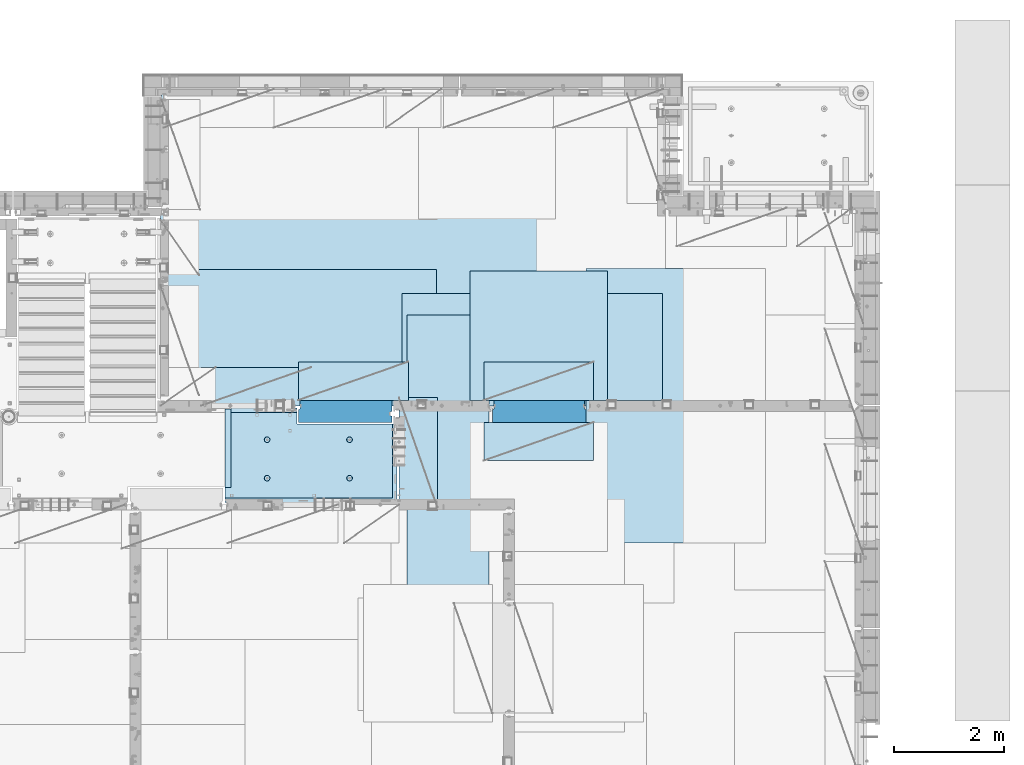
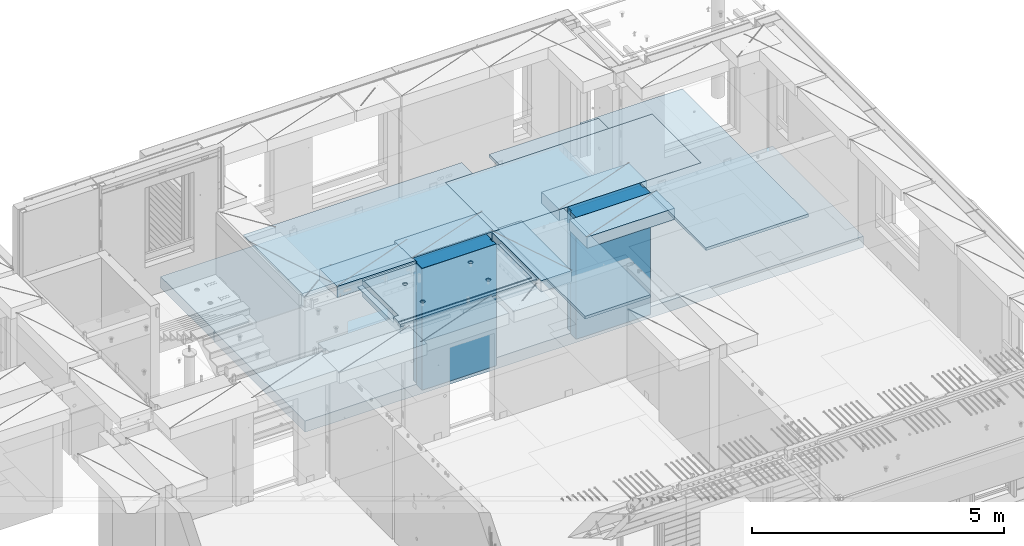
# One storey, part 189 of 325: 12 plates, 2 slabs, 14 elements without a shape of their own.
"""IFC2X3 building model written with IfcOpenShell, lengths in millimetres."""

from ifc_helpers import new_model, si_unit, frame, origin_with_axes, place, context, subcontext, project, spatial, faceted_brep, material, type_object, element, aggregate, save


model = new_model("IFC2X3")

# Units and contexts
model_context = context("Model", 3, precision=1e-05, world=origin_with_axes())
body_context = subcontext(model_context, "Body", "Model", "MODEL_VIEW")
ifc_project = project(units=[si_unit("LENGTHUNIT", "METRE", prefix="MILLI"), si_unit("AREAUNIT", "SQUARE_METRE"), si_unit("VOLUMEUNIT", "CUBIC_METRE"), si_unit("MASSUNIT", "GRAM", prefix="KILO"), si_unit("TIMEUNIT", "SECOND"), si_unit("PLANEANGLEUNIT", "RADIAN"), si_unit("SOLIDANGLEUNIT", "STERADIAN"), si_unit("THERMODYNAMICTEMPERATUREUNIT", "DEGREE_CELSIUS"), si_unit("LUMINOUSINTENSITYUNIT", "LUMEN")], contexts=[model_context])

# Site, building, storey
site_placement = place(None, origin_with_axes())
site = spatial("IfcSite", under=ifc_project, at=site_placement, CompositionType="ELEMENT")
building_placement = place(site_placement, origin_with_axes())
building = spatial("IfcBuilding", under=site, at=building_placement, CompositionType="ELEMENT")
storey_placement = place(building_placement, origin_with_axes())
storey = spatial("IfcBuildingStorey", under=building, at=storey_placement, Name="1", CompositionType="ELEMENT", Elevation=0.0)

# Assembly, slab
assembly_1_placement = place(storey_placement, origin_with_axes())
assembly_1 = element("IfcElementAssembly", 1, at=assembly_1_placement, inside=storey, AssemblyPlace="NOTDEFINED", PredefinedType="REINFORCEMENT_UNIT")
ifc_material_1 = material(Name="CONCRETE/C25/30")
slab_type_1 = type_object("IfcSlabType", PredefinedType="NOTDEFINED")
slab_1_placement = place(assembly_1_placement, frame((26570.0059390845, 15220.0026483125, 84620.0), z_axis=(-0.999999999997437, -2.26400000064461e-06, 0.0), x_axis=(-1.19799915409591e-06, 0.999999999999282, 0.0)))
slab_1 = element("IfcSlab", 2, at=slab_1_placement, type_object=slab_type_1, material=ifc_material_1, PredefinedType="FLOOR", context=body_context, shape_type="Brep", body=[
    faceted_brep([(260.000036693442, 30.0, 20.0001116859203), (260.00040878505, 30.0, 210.00282380305), (760.000392750888, 30.0, 210.001882803081), (760.000035167954, 30.0, 20.0003241859195), (259.999997532928, 50.0008466322761, 0.000110715616756352), (259.999997531775, 130.0, 4.72937244921923e-11), (260.00040878505, 130.0, 210.00282380305), (260.00003669344, 50.0008466322906, 20.0001116859239), (760.000392750888, 130.0, 210.001882803081), (759.999997530887, 50.0009701322706, 0.00188280345173553), (760.000035167954, 50.0009701322851, 20.0003241859267), (759.999997530887, 130.0, 1.4915713109076e-10), (0.0, 130.0, -1.81898940354586e-12), (0.0, 50.0007830199902, -3.63797880709171e-12), (2.23492861550767e-06, 50.0007830199902, 20.0000012144774), (0.00314200731554592, 50.0009709416772, 1679.99820316408), (0.00316042736994859, 130.0, 1679.99820316404), (20.0042037197236, 50.0007871208509, 20.0000019346335), (20.0050448999082, 50.0009732451872, 1679.9981655205), (20.0051981998968, 30.0, 1979.99816552074), (210.003723882246, 30.0, 1979.99780794351), (210.003159282247, 30.0, 1679.99780794404), (20.0050448999027, 30.0, 1679.9981655205), (20.0057858500695, 50.0011356208415, 3129.99855788155), (0.00588817475545511, 50.0011356208415, 3129.99536132812), (0.00371018100122456, 50.0010050132987, 1979.99820316354), (20.0051981998986, 50.0010068401461, 1979.99816552074), (1720.00727399273, -49.9988643791585, 3014.99216831216), (1700.0058891816, -49.9988643791585, 3014.99217713277), (1700.0058891816, 9.99999999994179, 3014.99217713277), (270.007273993393, 9.99999999994179, 3014.99280776216), (270.007273993393, -130.000000000058, 3014.99280776216), (1640.00591170533, -130.000000000058, 3014.99220359276), (1640.00591170533, -110.000000000058, 3014.99220359276), (1720.00727399273, -110.000000000058, 3014.99216831216), (1700.00578510373, 9.99999999994179, 3129.99536132812), (270.007324709519, 9.99999999994179, 3129.99536132812), (1700.00588013352, 9.99999999994179, 3024.99005271558), (270.007324709519, -130.0, 3129.99536132812), (0.0, -49.9992169800098, -3.63797880709171e-12), (1.81898940354586e-12, -110.000000000058, 0.0), (0.00588817475545511, -110.0, 3129.99536132812), (0.00588817475545511, -49.9988643791585, 3129.99536132812), (2.27349282795331e-05, -49.9992169800098, 20.000001214441), (40.0000000237706, -110.0, 0.00323799208854325), (40.0000056179106, -110.0, 80.000116817555), (80.0001648500238, -110.0, 80.0001140175445), (80.0058896111077, -110.0, 3129.99536132811), (80.0001648500238, -130.0, 80.0001140175445), (80.0058896111077, -130.0, 3129.99536132812), (458.262860973307, -110.000000000015, 813.90255309167), (472.201273869185, -110.000000000015, 821.004529187678), (483.262860973307, -110.000000000015, 832.066116291804), (490.364837069317, -110.000000000015, 846.004529187678), (492.812011254558, -110.000000000015, 861.455378906427), (490.364837069317, -110.000000000015, 876.906228625172), (483.262860973307, -110.000000000015, 890.844641521049), (472.201273869185, -110.000000000015, 901.906228625176), (458.262860973306, -110.000000000015, 909.008204721184), (442.81201125456, -110.000000000015, 911.455378906427), (427.361161535811, -110.000000000015, 909.008204721184), (413.422748639936, -110.000000000015, 901.906228625176), (402.361161535813, -110.000000000015, 890.844641521046), (395.259185439802, -110.000000000015, 876.906228625176), (392.81201125456, -110.000000000015, 861.455378906427), (395.259185439802, -110.000000000015, 846.004529187681), (402.361161535813, -110.000000000015, 832.0661162918), (413.422748639936, -110.000000000015, 821.004529187678), (427.361161535813, -110.000000000015, 813.90255309167), (442.812011254558, -110.000000000015, 811.455378906427), (458.965172324157, -130.0, 811.741061009179), (442.812011254558, -130.0, 809.182651633699), (473.537149442574, -130.0, 819.165854200462), (485.101535960521, -130.0, 830.730240718414), (492.526329151806, -130.0, 845.302217836826), (495.084738527285, -130.0, 861.45537890643), (492.526329151804, -130.0, 877.608539976027), (485.101535960521, -130.0, 892.180517094443), (473.537149442574, -130.0, 903.744903612387), (458.965172324157, -130.0, 911.16969680367), (442.81201125456, -130.0, 913.728106179151), (426.658850184962, -130.0, 911.169696803674), (412.086873066544, -130.0, 903.744903612391), (400.522486548598, -130.0, 892.180517094443), (393.097693357315, -130.0, 877.608539976027), (390.539283981834, -130.0, 861.455378906427), (393.097693357317, -130.0, 845.302217836826), (400.522486548598, -130.0, 830.730240718414), (412.086873066544, -130.0, 819.165854200462), (426.658850184962, -130.0, 811.741061009183), (1158.26361347154, -110.000000000058, 2313.90608356011), (1172.20202636741, -110.000000000058, 2321.00805965612), (1183.26361347154, -110.000000000058, 2332.06964676024), (1190.36558956755, -110.000000000058, 2346.00805965611), (1192.81276375279, -110.000000000058, 2361.45890937486), (1190.36558956755, -110.000000000058, 2376.90975909361), (1183.26361347154, -110.000000000058, 2390.84817198949), (1172.20202636741, -110.000000000058, 2401.90975909361), (1158.26361347154, -110.000000000058, 2409.01173518962), (1142.81276375279, -110.000000000058, 2411.45890937487), (1127.36191403404, -110.000000000058, 2409.01173518962), (1113.42350113817, -110.000000000058, 2401.90975909361), (1102.36191403404, -110.000000000058, 2390.84817198948), (1095.25993793803, -110.000000000058, 2376.90975909361), (1092.81276375279, -110.000000000058, 2361.45890937486), (1095.25993793803, -110.000000000058, 2346.00805965612), (1102.36191403404, -110.000000000058, 2332.06964676024), (1113.42350113817, -110.000000000058, 2321.00805965611), (1127.36191403405, -110.000000000058, 2313.90608356011), (1142.81276375279, -110.000000000058, 2311.45890937486), (1158.96592482239, -130.000000000044, 2311.74459147762), (1142.81276375279, -130.000000000044, 2309.18618210214), (1173.5379019408, -130.000000000044, 2319.1693846689), (1185.10228845875, -130.000000000044, 2330.73377118685), (1192.52708165004, -130.000000000044, 2345.30574830526), (1195.08549102551, -130.000000000044, 2361.45890937486), (1192.52708165004, -130.000000000044, 2377.61207044447), (1185.10228845875, -130.000000000044, 2392.18404756288), (1173.5379019408, -130.000000000044, 2403.74843408083), (1158.96592482239, -130.000000000044, 2411.17322727211), (1142.81276375279, -130.000000000044, 2413.73163664759), (1126.65960268319, -130.000000000044, 2411.17322727211), (1112.08762556478, -130.000000000044, 2403.74843408083), (1100.52323904683, -130.000000000044, 2392.18404756287), (1093.09844585554, -130.000000000044, 2377.61207044447), (1090.54003648007, -130.000000000044, 2361.45890937486), (1093.09844585555, -130.000000000044, 2345.30574830526), (1100.52323904683, -130.000000000044, 2330.73377118685), (1112.08762556478, -130.000000000044, 2319.1693846689), (1126.65960268319, -130.000000000044, 2311.74459147762), (1158.26322681425, -110.000000000029, 813.902566246979), (1172.20163971013, -110.000000000029, 821.004542342987), (1183.26322681425, -110.000000000029, 832.066129447114), (1190.36520291026, -110.000000000029, 846.004542342987), (1192.8123770955, -110.000000000029, 861.455392061736), (1190.36520291026, -110.000000000029, 876.906241780482), (1183.26322681425, -110.000000000029, 890.844654676363), (1172.20163971012, -110.000000000029, 901.906241780485), (1158.26322681425, -110.000000000029, 909.008217876493), (1142.8123770955, -110.000000000029, 911.455392061736), (1127.36152737675, -110.000000000029, 909.008217876493), (1113.42311448088, -110.000000000029, 901.906241780485), (1102.36152737675, -110.000000000029, 890.844654676359), (1095.25955128074, -110.000000000029, 876.906241780485), (1092.8123770955, -110.000000000029, 861.45539206174), (1095.25955128074, -110.000000000029, 846.004542342991), (1102.36152737675, -110.000000000029, 832.06612944711), (1113.42311448088, -110.000000000029, 821.004542342987), (1127.36152737675, -110.000000000029, 813.902566246979), (1142.8123770955, -110.000000000029, 811.455392061736), (1158.9655381651, -130.000000000029, 811.741074164489), (1142.8123770955, -130.000000000029, 809.182664789012), (1173.53751528352, -130.000000000029, 819.165867355772), (1185.10190180146, -130.000000000029, 830.730253873724), (1192.52669499275, -130.000000000029, 845.302230992136), (1195.08510436823, -130.000000000029, 861.45539206174), (1192.52669499275, -130.000000000029, 877.608553131337), (1185.10190180146, -130.000000000029, 892.180530249756), (1173.53751528351, -130.000000000029, 903.744916767697), (1158.9655381651, -130.000000000029, 911.16970995898), (1142.8123770955, -130.000000000029, 913.728119334461), (1126.6592160259, -130.000000000029, 911.169709958984), (1112.08723890749, -130.000000000029, 903.7449167677), (1100.52285238954, -130.000000000029, 892.180530249752), (1093.09805919825, -130.000000000029, 877.608553131337), (1090.53964982277, -130.000000000015, 861.455392061736), (1093.09805919826, -130.000000000015, 845.302230992136), (1100.52285238954, -130.000000000015, 830.730253873724), (1112.08723890749, -130.000000000015, 819.165867355776), (1126.6592160259, -130.000000000015, 811.741074164493), (458.263613472778, -110.000000000058, 2313.90740096011), (472.202026368655, -110.000000000058, 2321.00937705611), (483.263613472776, -110.000000000058, 2332.07096416024), (490.365589568788, -110.000000000058, 2346.00937705611), (492.812763754029, -110.000000000058, 2361.46022677486), (490.365589568788, -110.000000000058, 2376.91107649361), (483.263613472778, -110.000000000058, 2390.84948938949), (472.202026368655, -110.000000000058, 2401.91107649361), (458.263613472776, -110.000000000058, 2409.01305258962), (442.812763754029, -110.000000000058, 2411.46022677486), (427.361914035282, -110.000000000058, 2409.01305258962), (413.423501139407, -110.000000000058, 2401.91107649361), (402.361914035284, -110.000000000058, 2390.84948938949), (395.259937939272, -110.000000000058, 2376.91107649361), (392.812763754031, -110.000000000058, 2361.46022677486), (395.259937939272, -110.000000000058, 2346.00937705612), (402.361914035284, -110.000000000058, 2332.07096416024), (413.423501139407, -110.000000000058, 2321.00937705611), (427.361914035284, -110.000000000058, 2313.90740096011), (442.812763754029, -110.000000000058, 2311.46022677486), (458.965924823628, -130.000000000029, 2311.74590887762), (442.812763754029, -130.000000000029, 2309.18749950214), (473.537901942043, -130.000000000029, 2319.1707020689), (485.10228845999, -130.000000000029, 2330.73508858685), (492.527081651273, -130.000000000029, 2345.30706570526), (495.085491026754, -130.000000000029, 2361.46022677486), (492.527081651273, -130.000000000029, 2377.61338784446), (485.102288459992, -130.000000000029, 2392.18536496288), (473.537901942043, -130.000000000029, 2403.74975148082), (458.965924823628, -130.000000000029, 2411.1745446721), (442.812763754031, -130.000000000029, 2413.73295404758), (426.659602684433, -130.000000000029, 2411.17454467211), (412.087625566017, -130.000000000029, 2403.74975148082), (400.523239048071, -130.000000000029, 2392.18536496288), (393.098445856787, -130.000000000029, 2377.61338784446), (390.540036481307, -130.000000000029, 2361.46022677486), (393.098445856789, -130.000000000029, 2345.30706570526), (400.523239048067, -130.000000000029, 2330.73508858685), (412.087625566017, -130.000000000029, 2319.17070206891), (426.659602684433, -130.000000000029, 2311.74590887762), (1640.0069692709, -130.000000000058, 1820.00285259458), (1429.99412576448, -130.0, 80.0005450159842), (1430.00077693619, -130.000000000044, 1820.00324782623), (1640.0069692709, -110.000000000058, 1820.00285259458), (1720.00719314726, -110.000000000058, 1820.00270203416), (1720.00719416424, -49.9988643791585, 1820.00270203415), (1700.00697064704, -49.9988643791585, 1820.00273967458), (1430.00077693619, 129.999999999985, 1820.00324782623), (1720.00507313573, 130.0, 1820.00270203815), (1720.00696350816, 50.0011356208415, 1820.00270203459), (1700.00697064704, 50.0011356208415, 1820.00273967458), (1720.00548380367, 130.0, 2629.9953613439), (1720.00479630696, 50.0011356208415, 2629.99536134425), (1700.00623760369, 50.0011356208415, 2629.99539898154), (1700.00623760369, 30.0, 2629.99539898154), (1700.00578510373, 30.0, 3129.99535793147), (1510.00479630733, 130.0, 2629.99575656425), (1510.00479630733, 30.0, 2629.99575656425), (1510.00573730659, 130.0, 3129.99536132812), (1510.00573730659, 30.0, 3129.99536134176), (0.00588817475545511, 130.0, 3129.99536132812), (20.0057858500695, -49.9988643791585, 3129.99855788155), (0.00372479000361636, 130.0, 1979.99820316351), (210.003723882246, 130.0, 1979.99780794351), (210.003159282247, 130.0, 1679.99780794404), (20.0042037196527, -49.9988643791585, 20.0000019345935), (20.0041864226587, -49.9992128791491, 7.34271452529356e-07), (1429.99419217423, -49.9988643791585, 20.0006089333838), (1429.99420067423, -49.9988643791585, 0.000608933383773547), (80.0000146155362, -110.0, 0.000114017555461032), (1429.99735169022, -110.0, 7.40013310860377e-05), (1429.99412576448, -110.0, 80.0005450159842), (1429.99416747423, 50.0011356208415, 20.0006089334311), (1429.99417597423, 50.0011356208415, 0.000608933431067271), (1429.99735169022, 130.0, 2.80124368146062e-10), (20.0041864225386, 50.0007871208509, -3.03407432511449e-09)], [[[0, 1, 2, 3]], [[4, 5, 6, 1, 0, 7]], [[8, 2, 1, 6]], [[9, 10, 3, 2, 8, 11]], [[12, 13, 14, 15, 16]], [[14, 17, 18, 15]], [[19, 20, 21, 22]], [[23, 24, 25, 26]], [[27, 28, 29, 30, 31, 32, 33, 34]], [[35, 36, 30, 29, 37]], [[31, 30, 36, 38]], [[39, 40, 41, 42, 43]], [[44, 45, 46, 47, 41, 40]], [[48, 49, 47, 46]], [[50, 51, 52, 53, 54, 55, 56, 57, 58, 59, 60, 61, 62, 63, 64, 65, 66, 67, 68, 69]], [[70, 50, 69, 71]], [[72, 51, 50, 70]], [[73, 52, 51, 72]], [[74, 53, 52, 73]], [[75, 54, 53, 74]], [[76, 55, 54, 75]], [[77, 56, 55, 76]], [[78, 57, 56, 77]], [[79, 58, 57, 78]], [[80, 59, 58, 79]], [[81, 60, 59, 80]], [[82, 61, 60, 81]], [[83, 62, 61, 82]], [[84, 63, 62, 83]], [[85, 64, 63, 84]], [[86, 65, 64, 85]], [[87, 66, 65, 86]], [[88, 67, 66, 87]], [[89, 68, 67, 88]], [[71, 69, 68, 89]], [[90, 91, 92, 93, 94, 95, 96, 97, 98, 99, 100, 101, 102, 103, 104, 105, 106, 107, 108, 109]], [[110, 90, 109, 111]], [[112, 91, 90, 110]], [[113, 92, 91, 112]], [[114, 93, 92, 113]], [[115, 94, 93, 114]], [[116, 95, 94, 115]], [[117, 96, 95, 116]], [[118, 97, 96, 117]], [[119, 98, 97, 118]], [[120, 99, 98, 119]], [[121, 100, 99, 120]], [[122, 101, 100, 121]], [[123, 102, 101, 122]], [[124, 103, 102, 123]], [[125, 104, 103, 124]], [[126, 105, 104, 125]], [[127, 106, 105, 126]], [[128, 107, 106, 127]], [[129, 108, 107, 128]], [[111, 109, 108, 129]], [[130, 131, 132, 133, 134, 135, 136, 137, 138, 139, 140, 141, 142, 143, 144, 145, 146, 147, 148, 149]], [[150, 130, 149, 151]], [[152, 131, 130, 150]], [[153, 132, 131, 152]], [[154, 133, 132, 153]], [[155, 134, 133, 154]], [[156, 135, 134, 155]], [[157, 136, 135, 156]], [[158, 137, 136, 157]], [[159, 138, 137, 158]], [[160, 139, 138, 159]], [[161, 140, 139, 160]], [[162, 141, 140, 161]], [[163, 142, 141, 162]], [[164, 143, 142, 163]], [[165, 144, 143, 164]], [[166, 145, 144, 165]], [[167, 146, 145, 166]], [[168, 147, 146, 167]], [[169, 148, 147, 168]], [[151, 149, 148, 169]], [[170, 171, 172, 173, 174, 175, 176, 177, 178, 179, 180, 181, 182, 183, 184, 185, 186, 187, 188, 189]], [[190, 170, 189, 191]], [[192, 171, 170, 190]], [[193, 172, 171, 192]], [[194, 173, 172, 193]], [[195, 174, 173, 194]], [[196, 175, 174, 195]], [[197, 176, 175, 196]], [[198, 177, 176, 197]], [[199, 178, 177, 198]], [[200, 179, 178, 199]], [[201, 180, 179, 200]], [[202, 181, 180, 201]], [[203, 182, 181, 202]], [[204, 183, 182, 203]], [[205, 184, 183, 204]], [[206, 185, 184, 205]], [[207, 186, 185, 206]], [[208, 187, 186, 207]], [[209, 188, 187, 208]], [[191, 189, 188, 209]], [[210, 32, 31, 38, 49, 48, 211, 212], [208, 207, 206, 205, 204, 203, 202, 201, 200, 199, 198, 197, 196, 195, 194, 193, 192, 190, 191, 209], [168, 167, 166, 165, 164, 163, 162, 161, 160, 159, 158, 157, 156, 155, 154, 153, 152, 150, 151, 169], [128, 127, 126, 125, 124, 123, 122, 121, 120, 119, 118, 117, 116, 115, 114, 113, 112, 110, 111, 129], [88, 87, 86, 85, 84, 83, 82, 81, 80, 79, 78, 77, 76, 75, 74, 73, 72, 70, 71, 89]], [[33, 32, 210, 213]], [[34, 33, 213, 214]], [[27, 34, 214, 215]], [[28, 27, 215, 216]], [[214, 213, 210, 212, 217, 218, 219, 220, 216, 215]], [[219, 218, 221, 222]], [[220, 219, 222, 223]], [[35, 37, 29, 28, 216, 220, 223, 224, 225]], [[222, 221, 226, 227, 224, 223]], [[228, 229, 227, 226]], [[224, 227, 229, 225]], [[228, 230, 24, 23, 231, 42, 41, 47, 49, 38, 36, 35, 225, 229]], [[24, 230, 232, 25]], [[233, 20, 19, 26, 25, 232]], [[234, 21, 20, 233]], [[16, 15, 18, 22, 21, 234]], [[17, 235, 231, 23, 26, 19, 22, 18]], [[43, 42, 231, 235]], [[236, 39, 43, 235, 237, 238]], [[239, 44, 40, 39, 236, 238, 240]], [[46, 45, 44, 239, 240, 241]], [[48, 46, 241, 211]], [[240, 238, 237, 242, 243, 244, 217, 212, 211, 241]], [[244, 243, 9, 11]], [[6, 5, 12, 16, 234, 233, 232, 230, 228, 226, 221, 218, 217, 244, 11, 8]], [[245, 13, 12, 5, 4]], [[17, 14, 13, 245, 4, 7]], [[242, 237, 235, 17, 7, 0, 3, 10]], [[243, 242, 10, 9]]]),
])
aggregate(assembly_1, [slab_1])

assembly_2_placement = place(storey_placement, origin_with_axes())
assembly_2 = element("IfcElementAssembly", 3, at=assembly_2_placement, inside=storey, AssemblyPlace="NOTDEFINED", PredefinedType="REINFORCEMENT_UNIT")
ifc_material_2 = material(Name="CONCRETE/C30/37")
slab_type_2 = type_object("IfcSlabType", PredefinedType="NOTDEFINED")
slab_2_placement = place(assembly_2_placement, frame((22310.0, 16980.0, 81595.0), z_axis=(0.0, 1.0, 0.0), x_axis=(1.0, 0.0, 0.0)))
slab_2 = element("IfcSlab", 4, at=slab_2_placement, type_object=slab_type_2, material=ifc_material_2, PredefinedType="FLOOR", context=body_context, shape_type="Brep", body=[
    faceted_brep([(1.81898940354586e-12, -135.0, 1.81898940354586e-12), (-39.9985427856445, -135.0, -0.0037095642182976), (-39.9985427856445, 135.0, -0.0037095642182976), (1.81898940354586e-12, 135.0, 1.81898940354586e-12), (-40.0, -135.0, 3600.00048828125), (-40.0, 135.0, 3600.00048828125), (-20.0, -135.0, 3600.0), (-20.0, 135.0, 3600.0), (-20.0, -135.0, 5760.0), (-20.0, 135.0, 5760.0), (9149.9990234375, -135.0, 5760.0), (9149.9990234375, 135.0, 5760.0), (9149.9990234375, -135.0, 3600.00073242188), (9149.9990234375, 135.0, 3600.00073242188), (12750.0, -135.0, 3599.9951171875), (12750.0, 135.0, 3599.9951171875), (12750.0, -135.0, 0.0), (12750.0, 135.0, 0.0)], [[[0, 1, 2, 3]], [[1, 4, 5, 2]], [[4, 6, 7, 5]], [[6, 8, 9, 7]], [[8, 10, 11, 9]], [[10, 12, 13, 11]], [[12, 14, 15, 13]], [[14, 16, 17, 15]], [[16, 0, 3, 17]], [[5, 7, 9, 11, 13, 15, 17, 3, 2]], [[16, 14, 12, 10, 8, 6, 4, 1, 0]]]),
])
aggregate(assembly_2, [slab_2])

# Assembly, plate
assembly_3_placement = place(storey_placement, origin_with_axes())
assembly_3 = element("IfcElementAssembly", 5, at=assembly_3_placement, inside=storey, Name="Steel Assembly", AssemblyPlace="NOTDEFINED", PredefinedType="NOTDEFINED")
ifc_material_3 = material()
plate_type_1 = type_object("IfcPlateType", PredefinedType="NOTDEFINED")
plate_1_placement = place(assembly_3_placement, frame((22289.9998779297, 19460.0009765625, 84695.1), z_axis=(1.0, 0.0, 0.0), x_axis=(0.0, -1.0, 0.0)))
plate_1 = element("IfcPlate", 6, at=plate_1_placement, type_object=plate_type_1, material=ifc_material_3, context=body_context, shape_type="Brep", body=[
    faceted_brep([(0.0, -35.0, 0.0), (0.0, -35.0, 5000.0), (0.0, 35.0, 5000.0), (0.0, 35.0, 0.0), (2349.99951171875, -35.0, 5000.0), (2349.99951171875, 35.0, 5000.0), (2350.0, -35.0, 0.0), (2350.0, 35.0, 0.0)], [[[0, 1, 2, 3]], [[1, 4, 5, 2]], [[4, 6, 7, 5]], [[6, 0, 3, 7]], [[5, 7, 3, 2]], [[6, 4, 1, 0]]]),
])
aggregate(assembly_3, [plate_1])

assembly_4_placement = place(storey_placement, origin_with_axes())
assembly_4 = element("IfcElementAssembly", 7, at=assembly_4_placement, inside=storey, Name="Steel Assembly", AssemblyPlace="NOTDEFINED", PredefinedType="NOTDEFINED")
plate_2_placement = place(assembly_4_placement, frame((27902.5, 19430.0, 84695.1), z_axis=(1.0, 0.0, 0.0), x_axis=(0.0, -1.0, 0.0)))
plate_2 = element("IfcPlate", 8, at=plate_2_placement, type_object=plate_type_1, material=ifc_material_3, Name="1/2", context=body_context, shape_type="Brep", body=[
    faceted_brep([(0.0, -35.0, 0.0), (0.0, -35.0, 2500.0), (0.0, 35.0, 2500.0), (0.0, 35.0, 0.0), (2349.99951171875, -35.0, 2500.0), (2349.99951171875, 35.0, 2500.0), (2350.0, -35.0, 0.0), (2350.0, 35.0, 0.0)], [[[0, 1, 2, 3]], [[1, 4, 5, 2]], [[4, 6, 7, 5]], [[6, 0, 3, 7]], [[5, 7, 3, 2]], [[6, 4, 1, 0]]]),
])
aggregate(assembly_4, [plate_2])

assembly_5_placement = place(storey_placement, origin_with_axes())
assembly_5 = element("IfcElementAssembly", 9, at=assembly_5_placement, inside=storey, Name="Steel Assembly", AssemblyPlace="NOTDEFINED", PredefinedType="NOTDEFINED")
plate_3_placement = place(assembly_5_placement, frame((32360.0, 19480.0, 84695.1), z_axis=(0.0, -1.0, 0.0), x_axis=(-1.0, 3.00000001838171e-08, 0.0)))
plate_3 = element("IfcPlate", 10, at=plate_3_placement, type_object=plate_type_1, material=ifc_material_3, context=body_context, shape_type="Brep", body=[
    faceted_brep([(0.0, -35.0, 0.0), (0.0, -35.0, 5000.0), (0.0, 35.0, 5000.0), (0.0, 35.0, 0.0), (2349.99951171875, -35.0, 5000.0), (2349.99951171875, 35.0, 5000.0), (2350.0, -35.0, 0.0), (2350.0, 35.0, 0.0)], [[[0, 1, 2, 3]], [[1, 4, 5, 2]], [[4, 6, 7, 5]], [[6, 0, 3, 7]], [[5, 7, 3, 2]], [[6, 4, 1, 0]]]),
])
aggregate(assembly_5, [plate_3])

assembly_6_placement = place(storey_placement, origin_with_axes())
assembly_6 = element("IfcElementAssembly", 11, at=assembly_6_placement, inside=storey, Name="Steel Assembly", AssemblyPlace="NOTDEFINED", PredefinedType="NOTDEFINED")
plate_type_2 = type_object("IfcPlateType", PredefinedType="NOTDEFINED")
plate_4_placement = place(assembly_6_placement, frame((28250.0000122641, 18630.0, 84695.1000003815), z_axis=(0.0, -1.0, 0.0), x_axis=(-1.0, 3.00000001838171e-08, 0.0)))
plate_4 = element("IfcPlate", 12, at=plate_4_placement, type_object=plate_type_2, material=ifc_material_3, context=body_context, shape_type="Brep", body=[
    faceted_brep([(0.0, -35.0, 0.0), (0.0, -35.0, 5000.0), (0.0, 35.0, 5000.0), (0.0, 35.0, 0.0), (1499.99951171875, -35.0, 5000.0), (1499.99951171875, 35.0, 5000.0), (1500.0, -35.0, 0.0), (1500.0, 35.0, 0.0)], [[[0, 1, 2, 3]], [[1, 4, 5, 2]], [[4, 6, 7, 5]], [[6, 0, 3, 7]], [[5, 7, 3, 2]], [[6, 4, 1, 0]]]),
])
aggregate(assembly_6, [plate_4])

assembly_7_placement = place(storey_placement, origin_with_axes())
assembly_7 = element("IfcElementAssembly", 13, at=assembly_7_placement, inside=storey, Name="Steel Assembly", AssemblyPlace="NOTDEFINED", PredefinedType="NOTDEFINED")
plate_type_3 = type_object("IfcPlateType", PredefinedType="NOTDEFINED")
plate_5_placement = place(assembly_7_placement, frame((23010.0008542386, 16980.0001036336, 84595.3), z_axis=(0.0, 1.0, 0.0), x_axis=(1.0, 0.0, 0.0)))
plate_5 = element("IfcPlate", 14, at=plate_5_placement, type_object=plate_type_3, material=ifc_material_3, Name="RE1", context=body_context, shape_type="Brep", body=[
    faceted_brep([(1.81898940354586e-12, -135.0, 1.81898940354586e-12), (0.0, -135.0, 699.999999999996), (0.0, 135.0, 699.999999999996), (1.81898940354586e-12, 135.0, 1.81898940354586e-12), (1999.99951171875, -135.0, 699.999999999993), (1999.99951171875, 135.0, 699.999999999993), (2000.0, -135.0, -3.63797880709171e-12), (2000.0, 135.0, -3.63797880709171e-12)], [[[0, 1, 2, 3]], [[1, 4, 5, 2]], [[4, 6, 7, 5]], [[6, 0, 3, 7]], [[5, 7, 3, 2]], [[6, 4, 1, 0]]]),
])
aggregate(assembly_7, [plate_5])

assembly_8_placement = place(storey_placement, origin_with_axes())
assembly_8 = element("IfcElementAssembly", 15, at=assembly_8_placement, inside=storey, Name="Steel Assembly", AssemblyPlace="NOTDEFINED", PredefinedType="NOTDEFINED")
plate_6_placement = place(assembly_8_placement, frame((30152.4991457614, 16679.9998963664, 84595.3), z_axis=(0.0, -1.0, 0.0), x_axis=(-1.0, 3.00000001838171e-08, 0.0)))
plate_6 = element("IfcPlate", 16, at=plate_6_placement, type_object=plate_type_3, material=ifc_material_3, Name="RE1", context=body_context, shape_type="Brep", body=[
    faceted_brep([(1.81898940354586e-12, -135.0, 1.81898940354586e-12), (0.0, -135.0, 699.999999999996), (0.0, 135.0, 699.999999999996), (1.81898940354586e-12, 135.0, 1.81898940354586e-12), (1999.99951171875, -135.0, 699.999999999993), (1999.99951171875, 135.0, 699.999999999993), (2000.0, -135.0, -3.63797880709171e-12), (2000.0, 135.0, -3.63797880709171e-12)], [[[0, 1, 2, 3]], [[1, 4, 5, 2]], [[4, 6, 7, 5]], [[6, 0, 3, 7]], [[5, 7, 3, 2]], [[6, 4, 1, 0]]]),
])
aggregate(assembly_8, [plate_6])

assembly_9_placement = place(storey_placement, origin_with_axes())
assembly_9 = element("IfcElementAssembly", 17, at=assembly_9_placement, inside=storey, Name="Steel Assembly", AssemblyPlace="NOTDEFINED", PredefinedType="NOTDEFINED")
plate_7_placement = place(assembly_9_placement, frame((28152.5008542386, 17080.0001036336, 84595.3), z_axis=(0.0, 1.0, 0.0), x_axis=(1.0, 0.0, 0.0)))
plate_7 = element("IfcPlate", 18, at=plate_7_placement, type_object=plate_type_3, material=ifc_material_3, Name="RE1", context=body_context, shape_type="Brep", body=[
    faceted_brep([(1.81898940354586e-12, -135.0, 1.81898940354586e-12), (0.0, -135.0, 699.999999999996), (0.0, 135.0, 699.999999999996), (1.81898940354586e-12, 135.0, 1.81898940354586e-12), (1999.99951171875, -135.0, 699.999999999993), (1999.99951171875, 135.0, 699.999999999993), (2000.0, -135.0, -3.63797880709171e-12), (2000.0, 135.0, -3.63797880709171e-12)], [[[0, 1, 2, 3]], [[1, 4, 5, 2]], [[4, 6, 7, 5]], [[6, 0, 3, 7]], [[5, 7, 3, 2]], [[6, 4, 1, 0]]]),
])
aggregate(assembly_9, [plate_7])

assembly_10_placement = place(storey_placement, origin_with_axes())
assembly_10 = element("IfcElementAssembly", 19, at=assembly_10_placement, inside=storey, Name="Steel Assembly", AssemblyPlace="NOTDEFINED", PredefinedType="NOTDEFINED")
plate_8_placement = place(assembly_10_placement, frame((24780.0008542386, 17080.0001036336, 84595.3), z_axis=(0.0, 1.0, 0.0), x_axis=(1.0, 0.0, 0.0)))
plate_8 = element("IfcPlate", 20, at=plate_8_placement, type_object=plate_type_3, material=ifc_material_3, Name="RE1", context=body_context, shape_type="Brep", body=[
    faceted_brep([(1.81898940354586e-12, -135.0, 1.81898940354586e-12), (0.0, -135.0, 699.999999999996), (0.0, 135.0, 699.999999999996), (1.81898940354586e-12, 135.0, 1.81898940354586e-12), (1999.99951171875, -135.0, 699.999999999993), (1999.99951171875, 135.0, 699.999999999993), (2000.0, -135.0, -3.63797880709171e-12), (2000.0, 135.0, -3.63797880709171e-12)], [[[0, 1, 2, 3]], [[1, 4, 5, 2]], [[4, 6, 7, 5]], [[6, 0, 3, 7]], [[5, 7, 3, 2]], [[6, 4, 1, 0]]]),
])
aggregate(assembly_10, [plate_8])

assembly_11_placement = place(storey_placement, origin_with_axes())
assembly_11 = element("IfcElementAssembly", 21, at=assembly_11_placement, inside=storey, Name="Steel Assembly", AssemblyPlace="NOTDEFINED", PredefinedType="NOTDEFINED")
plate_9_placement = place(assembly_11_placement, frame((26609.9998779297, 17130.0, 84595.3), z_axis=(1.0, 0.0, 0.0), x_axis=(0.0, -1.0, 0.0)))
plate_9 = element("IfcPlate", 22, at=plate_9_placement, type_object=plate_type_3, material=ifc_material_3, Name="RE1", context=body_context, shape_type="Brep", body=[
    faceted_brep([(1.81898940354586e-12, -135.0, 1.81898940354586e-12), (0.0, -135.0, 699.999999999996), (0.0, 135.0, 699.999999999996), (1.81898940354586e-12, 135.0, 1.81898940354586e-12), (1999.99951171875, -135.0, 699.999999999993), (1999.99951171875, 135.0, 699.999999999993), (2000.0, -135.0, -3.63797880709171e-12), (2000.0, 135.0, -3.63797880709171e-12)], [[[0, 1, 2, 3]], [[1, 4, 5, 2]], [[4, 6, 7, 5]], [[6, 0, 3, 7]], [[5, 7, 3, 2]], [[6, 4, 1, 0]]]),
])
aggregate(assembly_11, [plate_9])

assembly_12_placement = place(storey_placement, origin_with_axes())
assembly_12 = element("IfcElementAssembly", 23, at=assembly_12_placement, inside=storey, AssemblyPlace="NOTDEFINED", PredefinedType="REINFORCEMENT_UNIT")
plate_type_4 = type_object("IfcPlateType", PredefinedType="NOTDEFINED")
plate_10_placement = place(assembly_12_placement, frame((31402.0004441066, 19019.9993561238, 84725.45), z_axis=(0.0, -1.0, 0.0), x_axis=(-1.0, 3.00000001838171e-08, 0.0)))
plate_10 = element("IfcPlate", 24, at=plate_10_placement, type_object=plate_type_4, material=ifc_material_3, context=body_context, shape_type="Brep", body=[
    faceted_brep([(0.0, -5.0, 0.0), (0.0, -5.0, 1939.99963378906), (0.0, 5.0, 1939.99963378906), (0.0, 5.0, 0.0), (4742.00048828125, -5.0, 1939.99963378906), (4742.00048828125, 5.0, 1939.99963378906), (4742.00048828125, -5.0, 0.0), (4742.00048828125, 5.0, 0.0), (92.0009613037109, -5.0, 0.0), (92.0009613037109, 5.0, 0.0)], [[[0, 1, 2, 3]], [[1, 4, 5, 2]], [[4, 6, 7, 5]], [[6, 8, 9, 7]], [[8, 0, 3, 9]], [[5, 7, 9, 3, 2]], [[8, 6, 4, 1, 0]]]),
])
aggregate(assembly_12, [plate_10])

assembly_13_placement = place(storey_placement, origin_with_axes())
assembly_13 = element("IfcElementAssembly", 25, at=assembly_13_placement, inside=storey, Name="Steel Assembly", AssemblyPlace="NOTDEFINED", PredefinedType="NOTDEFINED")
ifc_material_4 = material()
plate_type_5 = type_object("IfcPlateType", PredefinedType="NOTDEFINED")
plate_11_placement = place(assembly_13_placement, frame((24780.0, 16680.0, 83255.6000003815), z_axis=(0.0, 1.0, 0.0), x_axis=(1.0, 0.0, 0.0)))
plate_11 = element("IfcPlate", 26, at=plate_11_placement, type_object=plate_type_5, material=ifc_material_4, context=body_context, shape_type="Brep", body=[
    faceted_brep([(1699.99914550781, -1475.0, 110.0), (1699.99914550781, 1475.0, 110.0), (1669.99914550781, 1475.0, 110.0), (1669.99914550781, -1475.00000000001, 110.0), (1669.99914550781, 1475.0, 200.0), (1669.99914550781, -1475.00000000001, 200.0), (1699.99914550781, -1475.0, 200.0), (1699.99914550781, 1475.0, 200.0), (1699.99914550781, -1475.0, 3.63797880709171e-12), (0.0, -1475.0, 0.0), (0.0, 1475.0, 0.0), (1699.99914550781, 1475.0, 3.63797880709171e-12), (0.0, -1475.0, 230.0), (0.0, 1475.0, 230.0), (30.0, -1475.0, 243.0), (30.0, 1475.0, 243.0), (30.0, -1475.0, 400.0), (30.0, 1475.0, 400.0), (1699.99914550781, -1475.0, 400.0), (1699.99914550781, 1475.0, 400.0)], [[[0, 1, 2, 3]], [[3, 2, 4, 5]], [[6, 5, 4, 7]], [[8, 9, 10, 11]], [[10, 9, 12, 13]], [[14, 15, 13, 12]], [[16, 17, 15, 14]], [[18, 19, 17, 16]], [[19, 18, 6, 7]], [[2, 1, 11, 10, 13, 15, 17, 19, 7, 4]], [[8, 11, 1, 0]], [[18, 16, 14, 12, 9, 8, 0, 3, 5, 6]]]),
])
aggregate(assembly_13, [plate_11])

assembly_14_placement = place(storey_placement, origin_with_axes())
assembly_14 = element("IfcElementAssembly", 27, at=assembly_14_placement, inside=storey, Name="Steel Assembly", AssemblyPlace="NOTDEFINED", PredefinedType="NOTDEFINED")
plate_12_placement = place(assembly_14_placement, frame((28309.9999105288, 16680.0000293051, 83255.6000003815), z_axis=(0.0, 1.0, 0.0), x_axis=(1.0, 0.0, 0.0)))
plate_12 = element("IfcPlate", 28, at=plate_12_placement, type_object=plate_type_5, material=ifc_material_4, context=body_context, shape_type="Brep", body=[
    faceted_brep([(29.9999989126591, -1475.0, 243.000885767418), (29.9999989126591, 1475.0, 243.000885767418), (0.0, 1475.0, 230.000886222213), (0.0, -1475.0, 230.000886222213), (30.0000025741901, -1475.0, 399.999635204884), (30.0000025741901, 1475.0, 399.999633789063), (1700.00073242188, -1475.0, 0.0), (0.0, -1475.0, 0.0), (0.0, 1475.0, 0.0), (1700.00073242188, 1475.0, 0.0), (1700.00073242188, 1475.0, 230.001129150391), (1700.00041094652, -1475.0, 230.001129150391), (1670.00041094652, 1475.0, 243.001129150391), (1670.00041094652, -1475.0, 243.001129150391), (1670.00041094652, -1475.0, 399.999633789063), (1670.00041094652, 1475.0, 399.999633789063)], [[[0, 1, 2, 3]], [[4, 5, 1, 0]], [[6, 7, 8, 9]], [[6, 9, 10, 11]], [[11, 10, 12, 13]], [[14, 13, 12, 15]], [[3, 7, 6, 11, 13, 14, 4, 0]], [[8, 7, 3, 2]], [[15, 12, 10, 9, 8, 2, 1, 5]], [[14, 15, 5, 4]]]),
])
aggregate(assembly_14, [plate_12])

save(model, "model.ifc")
